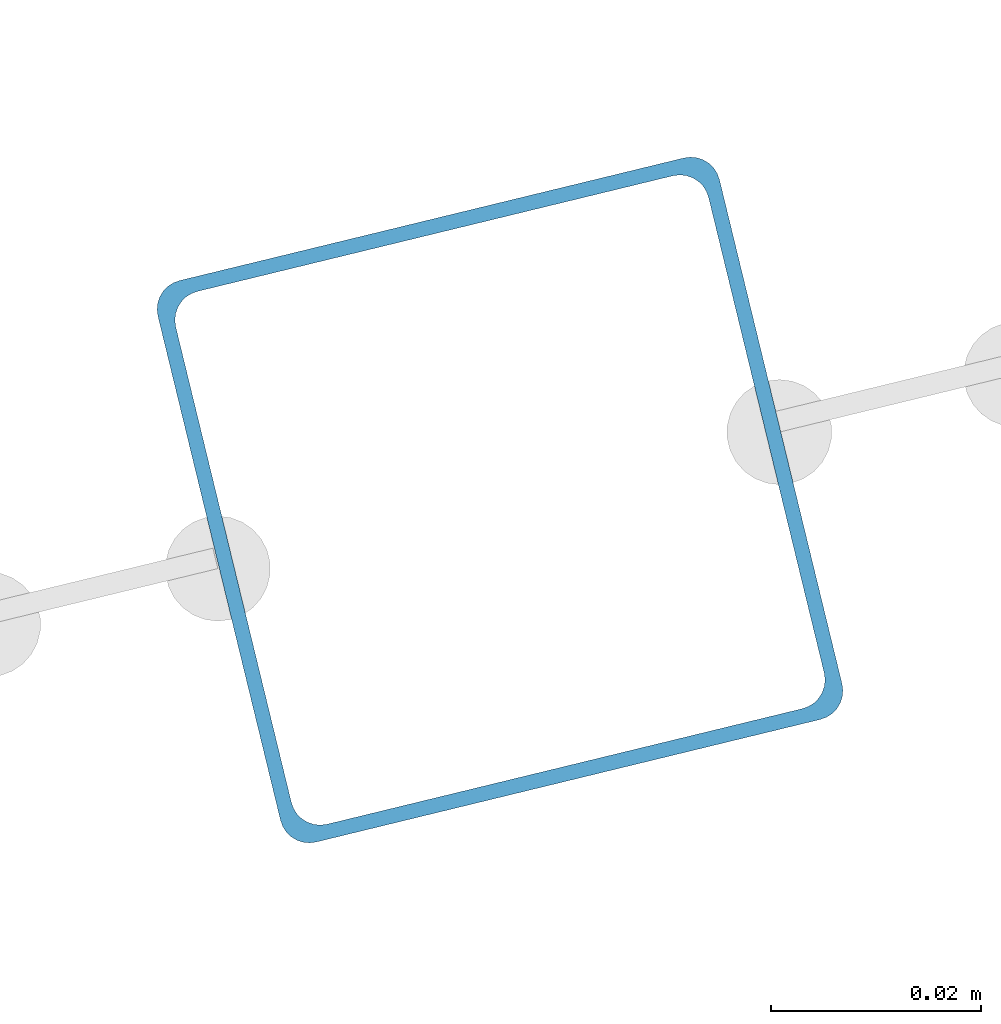
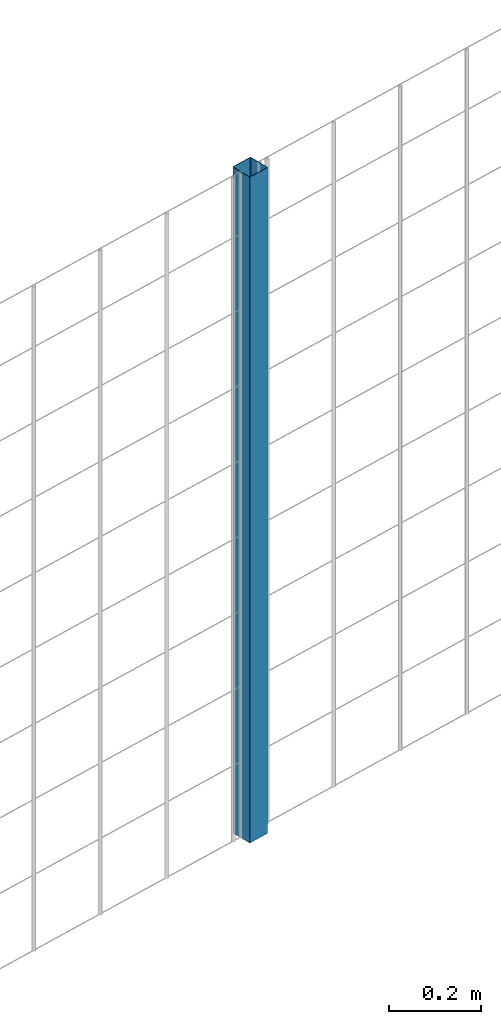
# One storey, part 2 of 10: 1 beam.
"""IFC2X3 building model written with IfcOpenShell, lengths in millimetres."""

from ifc_helpers import new_model, entity, si_unit, converted_unit, derived_unit, direction, frame, frame_2d, origin, place, context, subcontext, project, spatial, polyline, circle_curve, parameter, trimmed, segment, composite_curve, outline, extrude, material, type_object, element, save


model = new_model("IFC2X3")

# Units and contexts
model_context = context("Model", 3, precision=0.01, world=origin(), true_north=direction((6.12303176911189e-17, 1.0)))
body_context = subcontext(model_context, "Body", "Model", "MODEL_VIEW")
ifc_project = project(units=[si_unit("LENGTHUNIT", "METRE", prefix="MILLI"), si_unit("AREAUNIT", "SQUARE_METRE"), si_unit("VOLUMEUNIT", "CUBIC_METRE"), converted_unit("PLANEANGLEUNIT", "DEGREE", entity("IfcRatioMeasure", 0.0174532925199433), si_unit("PLANEANGLEUNIT", "RADIAN"), dimensions=[0, 0, 0, 0, 0, 0, 0]), si_unit("MASSUNIT", "GRAM", prefix="KILO"), derived_unit("MASSDENSITYUNIT", [(si_unit("MASSUNIT", "GRAM", prefix="KILO"), 1), (si_unit("LENGTHUNIT", "METRE"), -3)]), derived_unit("MOMENTOFINERTIAUNIT", [(si_unit("LENGTHUNIT", "METRE"), 4)]), si_unit("TIMEUNIT", "SECOND"), si_unit("FREQUENCYUNIT", "HERTZ"), si_unit("THERMODYNAMICTEMPERATUREUNIT", "DEGREE_CELSIUS"), derived_unit("THERMALTRANSMITTANCEUNIT", [(si_unit("MASSUNIT", "GRAM", prefix="KILO"), 1), (si_unit("THERMODYNAMICTEMPERATUREUNIT", "KELVIN"), -1), (si_unit("TIMEUNIT", "SECOND"), -3)]), derived_unit("VOLUMETRICFLOWRATEUNIT", [(si_unit("LENGTHUNIT", "METRE"), 3), (si_unit("TIMEUNIT", "SECOND"), -1)]), derived_unit("MASSFLOWRATEUNIT", [(si_unit("MASSUNIT", "GRAM", prefix="KILO"), 1), (si_unit("TIMEUNIT", "SECOND"), -1)]), derived_unit("ROTATIONALFREQUENCYUNIT", [(si_unit("TIMEUNIT", "SECOND"), -1)]), si_unit("ELECTRICCURRENTUNIT", "AMPERE"), si_unit("ELECTRICVOLTAGEUNIT", "VOLT"), si_unit("POWERUNIT", "WATT"), si_unit("FORCEUNIT", "NEWTON", prefix="KILO"), si_unit("ILLUMINANCEUNIT", "LUX"), si_unit("LUMINOUSFLUXUNIT", "LUMEN"), si_unit("LUMINOUSINTENSITYUNIT", "CANDELA"), derived_unit("USERDEFINED", [(si_unit("MASSUNIT", "GRAM", prefix="KILO"), -1), (si_unit("LENGTHUNIT", "METRE"), -2), (si_unit("TIMEUNIT", "SECOND"), 3), (si_unit("LUMINOUSFLUXUNIT", "LUMEN"), 1)]), derived_unit("LINEARVELOCITYUNIT", [(si_unit("LENGTHUNIT", "METRE"), 1), (si_unit("TIMEUNIT", "SECOND"), -1)]), si_unit("PRESSUREUNIT", "PASCAL"), derived_unit("USERDEFINED", [(si_unit("LENGTHUNIT", "METRE"), -2), (si_unit("MASSUNIT", "GRAM", prefix="KILO"), 1), (si_unit("TIMEUNIT", "SECOND"), -2)]), derived_unit("LINEARFORCEUNIT", [(si_unit("MASSUNIT", "GRAM", prefix="KILO"), 1), (si_unit("LENGTHUNIT", "METRE"), 1), (si_unit("TIMEUNIT", "SECOND"), -2), (si_unit("LENGTHUNIT", "METRE"), -1)]), derived_unit("PLANARFORCEUNIT", [(si_unit("MASSUNIT", "GRAM", prefix="KILO"), 1), (si_unit("LENGTHUNIT", "METRE"), 1), (si_unit("TIMEUNIT", "SECOND"), -2), (si_unit("LENGTHUNIT", "METRE"), -2)])], contexts=[model_context])

# Site, building, storey
site_placement = place(None, frame((19171.746869958, -72498.5768491146, 0.0), z_axis=(0.0, 0.0, 1.0), x_axis=(0.971695960795463, 0.236234967296933, 0.0)))
site = spatial("IfcSite", under=ifc_project, at=site_placement, CompositionType="ELEMENT")
building_placement = place(site_placement, origin())
building = spatial("IfcBuilding", under=site, at=building_placement, CompositionType="ELEMENT")
storey_placement = place(building_placement, origin())
storey = spatial("IfcBuildingStorey", under=building, at=storey_placement, CompositionType="ELEMENT", Elevation=0.0)

# Beam
ifc_material = material()
beam_type = type_object("IfcBeamType", PredefinedType="NOTDEFINED")
beam_placement = place(storey_placement, frame((5171.04333907997, 95.9047277640865, 699.02077554174), z_axis=(1.0, 0.0, 0.0), x_axis=(0.0, 0.0, 1.0)))
element("IfcBeam", 1, at=beam_placement, inside=storey, type_object=beam_type, material=ifc_material, context=body_context, shape_type="SweptSolid", body=[
    extrude(outline(composite_curve([segment(trimmed(circle_curve(frame_2d((24.6999999999999, -24.7000000000008), x_axis=(1.0, 0.0)), 2.79999999999974), [parameter(269.999999999999)], [parameter(1.32311074748882e-12)], True, "PARAMETER"), True, "CONTINUOUS"), segment(polyline([(27.4999999999996, -24.7000000000008), (27.4999999999983, 24.6999999999999)]), True, "CONTINUOUS"), segment(trimmed(circle_curve(frame_2d((24.6999999999998, 24.6999999999999), x_axis=(1.0, 0.0)), 2.79999999999845), [parameter(1.32311074748882e-12)], [parameter(90.0000000000001)], True, "PARAMETER"), True, "CONTINUOUS"), segment(polyline([(24.6999999999999, 27.4999999999981), (-24.7000000000002, 27.499999999998)]), True, "CONTINUOUS"), segment(trimmed(circle_curve(frame_2d((-24.7000000000002, 24.6999999999997), x_axis=(1.0, 0.0)), 2.79999999999845), [parameter(90.0000000000001)], [parameter(180.0)], True, "PARAMETER"), True, "CONTINUOUS"), segment(polyline([(-27.4999999999986, 24.6999999999997), (-27.4999999999986, -24.6999999999999)]), True, "CONTINUOUS"), segment(trimmed(circle_curve(frame_2d((-24.7000000000001, -24.7000000000009), x_axis=(1.0, 0.0)), 2.79999999999845), [parameter(180.0)], [parameter(269.999999999998)], True, "PARAMETER"), True, "CONTINUOUS"), segment(polyline([(-24.7000000000002, -27.4999999999992), (24.6999999999999, -27.5000000000002)]), True, "CONTINUOUS")], self_intersect=False), holes=[composite_curve([segment(polyline([(23.2999999999995, -26.1000000000005), (-23.3000000000005, -26.0999999999995)]), True, "CONTINUOUS"), segment(trimmed(circle_curve(frame_2d((-23.3000000000005, -23.3000000000002), x_axis=(1.0, 0.0)), 2.79999999999973), [parameter(180.0)], [parameter(270.0)], True, "PARAMETER"), False, "CONTINUOUS"), segment(polyline([(-26.1000000000002, -23.3000000000002), (-26.1000000000002, 23.3000000000001)]), True, "CONTINUOUS"), segment(trimmed(circle_curve(frame_2d((-23.3000000000005, 23.3000000000001), x_axis=(1.0, 0.0)), 2.79999999999973), [parameter(90.0000000000004)], [parameter(180.0)], True, "PARAMETER"), False, "CONTINUOUS"), segment(polyline([(-23.3000000000005, 26.0999999999994), (23.2999999999995, 26.0999999999995)]), True, "CONTINUOUS"), segment(trimmed(circle_curve(frame_2d((23.2999999999995, 23.3000000000002), x_axis=(1.0, 0.0)), 2.79999999999973), [parameter(3.56222124323914e-13)], [parameter(90.0000000000004)], True, "PARAMETER"), False, "CONTINUOUS"), segment(polyline([(26.0999999999992, 23.3000000000002), (26.0999999999999, -23.3000000000001)]), True, "CONTINUOUS"), segment(trimmed(circle_curve(frame_2d((23.2999999999995, -23.3000000000001), x_axis=(1.0, 0.0)), 2.80000000000034), [parameter(270.0)], [parameter(4.57999874130747e-13)], True, "PARAMETER"), False, "CONTINUOUS")], self_intersect=False)]), frame((0.0, -29.0952722359147, 29.095272235914), z_axis=(1.0, 0.0, 0.0), x_axis=(0.0, -1.0, 0.0)), (0.0, 0.0, 1.0), 1765.97922445826),
])

save(model, "model.ifc")
